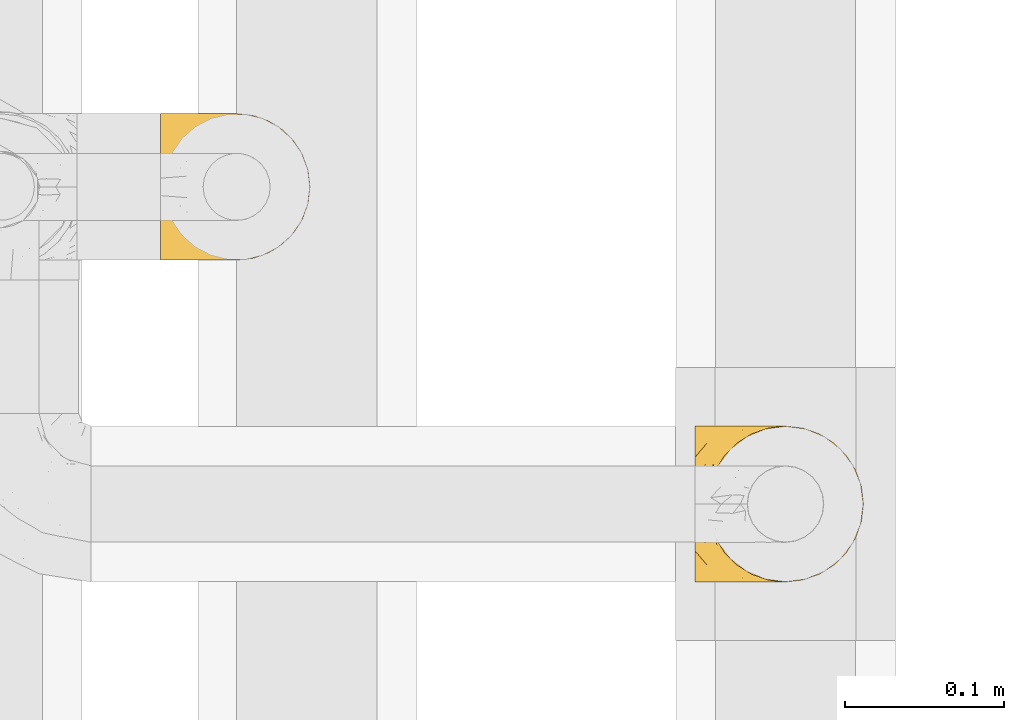
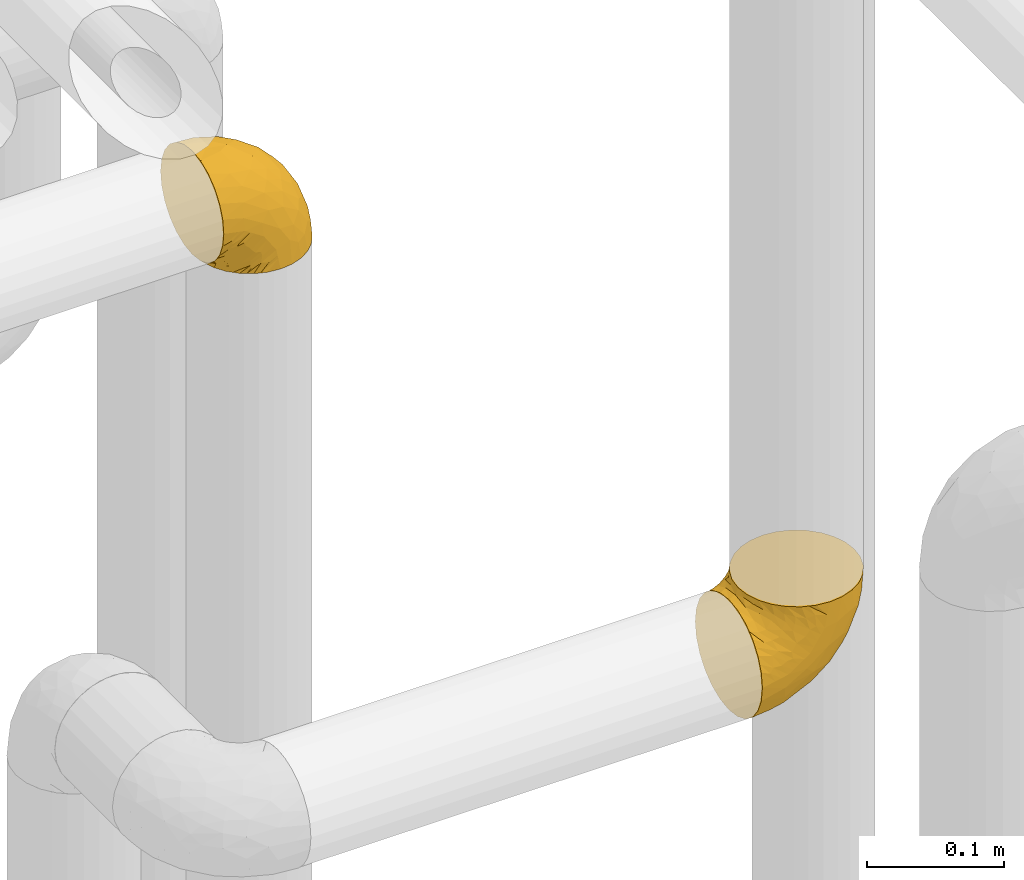
# One storey, part 223 of 827: 2 coverings.
"""IFC2X3 building model written with IfcOpenShell, lengths in millimetres."""

from ifc_helpers import new_model, entity, si_unit, converted_unit, derived_unit, direction, frame, origin, place, context, subcontext, project, spatial, faceted_brep, element, save


model = new_model("IFC2X3")

# Units and contexts
model_context = context("Model", 3, precision=0.01, world=origin(), true_north=direction((6.12303176911189e-17, 1.0)))
body_context = subcontext(model_context, "Body", "Model", "MODEL_VIEW")
ifc_project = project(units=[si_unit("LENGTHUNIT", "METRE", prefix="MILLI"), si_unit("AREAUNIT", "SQUARE_METRE"), si_unit("VOLUMEUNIT", "CUBIC_METRE"), converted_unit("PLANEANGLEUNIT", "DEGREE", entity("IfcRatioMeasure", 0.0174532925199433), si_unit("PLANEANGLEUNIT", "RADIAN"), dimensions=[0, 0, 0, 0, 0, 0, 0]), si_unit("MASSUNIT", "GRAM", prefix="KILO"), derived_unit("MASSDENSITYUNIT", [(si_unit("MASSUNIT", "GRAM", prefix="KILO"), 1), (si_unit("LENGTHUNIT", "METRE"), -3)]), derived_unit("MOMENTOFINERTIAUNIT", [(si_unit("LENGTHUNIT", "METRE"), 4)]), si_unit("TIMEUNIT", "SECOND"), si_unit("FREQUENCYUNIT", "HERTZ"), si_unit("THERMODYNAMICTEMPERATUREUNIT", "DEGREE_CELSIUS"), derived_unit("THERMALTRANSMITTANCEUNIT", [(si_unit("MASSUNIT", "GRAM", prefix="KILO"), 1), (si_unit("THERMODYNAMICTEMPERATUREUNIT", "KELVIN"), -1), (si_unit("TIMEUNIT", "SECOND"), -3)]), derived_unit("VOLUMETRICFLOWRATEUNIT", [(si_unit("LENGTHUNIT", "METRE"), 3), (si_unit("TIMEUNIT", "SECOND"), -1)]), derived_unit("MASSFLOWRATEUNIT", [(si_unit("MASSUNIT", "GRAM", prefix="KILO"), 1), (si_unit("TIMEUNIT", "SECOND"), -1)]), derived_unit("ROTATIONALFREQUENCYUNIT", [(si_unit("TIMEUNIT", "SECOND"), -1)]), si_unit("ELECTRICCURRENTUNIT", "AMPERE"), si_unit("ELECTRICVOLTAGEUNIT", "VOLT"), si_unit("POWERUNIT", "WATT"), si_unit("FORCEUNIT", "NEWTON", prefix="KILO"), si_unit("ILLUMINANCEUNIT", "LUX"), si_unit("LUMINOUSFLUXUNIT", "LUMEN"), si_unit("LUMINOUSINTENSITYUNIT", "CANDELA"), derived_unit("USERDEFINED", [(si_unit("MASSUNIT", "GRAM", prefix="KILO"), -1), (si_unit("LENGTHUNIT", "METRE"), -2), (si_unit("TIMEUNIT", "SECOND"), 3), (si_unit("LUMINOUSFLUXUNIT", "LUMEN"), 1)]), derived_unit("LINEARVELOCITYUNIT", [(si_unit("LENGTHUNIT", "METRE"), 1), (si_unit("TIMEUNIT", "SECOND"), -1)]), si_unit("PRESSUREUNIT", "PASCAL"), derived_unit("USERDEFINED", [(si_unit("LENGTHUNIT", "METRE"), -2), (si_unit("MASSUNIT", "GRAM", prefix="KILO"), 1), (si_unit("TIMEUNIT", "SECOND"), -2)]), derived_unit("LINEARFORCEUNIT", [(si_unit("MASSUNIT", "GRAM", prefix="KILO"), 1), (si_unit("LENGTHUNIT", "METRE"), 1), (si_unit("TIMEUNIT", "SECOND"), -2), (si_unit("LENGTHUNIT", "METRE"), -1)]), derived_unit("PLANARFORCEUNIT", [(si_unit("MASSUNIT", "GRAM", prefix="KILO"), 1), (si_unit("LENGTHUNIT", "METRE"), 1), (si_unit("TIMEUNIT", "SECOND"), -2), (si_unit("LENGTHUNIT", "METRE"), -2)])], contexts=[model_context])

# Site, building, storey
site_placement = place(None, origin())
site = spatial("IfcSite", under=ifc_project, at=site_placement, CompositionType="ELEMENT")
building_placement = place(site_placement, origin())
building = spatial("IfcBuilding", under=site, at=building_placement, CompositionType="ELEMENT")
storey_placement = place(building_placement, frame((0.0, 0.0, 28200.0)))
storey = spatial("IfcBuildingStorey", under=building, at=storey_placement, Name="08", CompositionType="ELEMENT", Elevation=28200.0)

# Coverings
covering_1_placement = place(storey_placement, frame((36161.44, 12505.34, 2549.25)))
element("IfcCovering", 1, at=covering_1_placement, inside=storey, Name=":ADSK_", ObjectType=":ADSK_", PredefinedType="INSULATION", context=body_context, shape_type="Brep", body=[
    faceted_brep([(58.6, 1.6, 107.75), (69.54, 2.83, 107.75), (79.93, 6.47, 107.75), (89.25, 12.32, 107.75), (97.03, 20.11, 107.75), (102.88, 29.43, 107.75), (106.51, 39.81, 107.75), (107.75, 50.75, 107.75), (106.51, 61.69, 107.75), (102.87, 72.08, 107.75), (97.02, 81.4, 107.75), (89.23, 89.18, 107.75), (79.91, 95.03, 107.75), (69.53, 98.66, 107.75), (58.6, 99.9, 107.75), (52.89, 99.25, 107.75), (47.65, 98.66, 107.75), (42.46, 96.84, 107.75), (37.26, 95.02, 107.75), (27.94, 89.17, 107.75), (20.16, 81.38, 107.75), (14.31, 72.06, 107.75), (10.68, 61.68, 107.75), (9.45, 50.75, 107.75), (10.68, 39.8, 107.75), (14.32, 29.41, 107.75), (20.17, 20.09, 107.75), (27.96, 12.31, 107.75), (37.28, 6.46, 107.75), (42.47, 4.64, 107.75), (47.66, 2.83, 107.75), (52.89, 2.24, 107.75), (55.75, 1.92, 107.75), (1.6, 63.47, 98.22), (1.6, 75.32, 93.31), (1.6, 80.41, 89.4), (1.6, 85.5, 85.5), (1.6, 89.4, 80.41), (1.6, 93.31, 75.32), (1.6, 95.77, 69.39), (1.6, 98.22, 63.47), (1.6, 99.14, 56.48), (1.6, 99.52, 53.61), (1.6, 99.9, 50.75), (1.6, 98.22, 38.02), (1.6, 93.31, 26.17), (1.6, 85.5, 15.99), (1.6, 75.32, 8.18), (1.6, 63.47, 3.27), (1.6, 50.75, 1.6), (1.6, 38.02, 3.27), (1.6, 26.17, 8.18), (1.6, 15.99, 15.99), (1.6, 8.18, 26.17), (1.6, 3.27, 38.02), (1.6, 1.6, 50.75), (1.6, 2.35, 56.48), (1.6, 3.27, 63.47), (1.6, 5.73, 69.39), (1.6, 8.18, 75.32), (1.6, 12.09, 80.41), (1.6, 15.99, 85.5), (1.6, 21.08, 89.4), (1.6, 26.17, 93.31), (1.6, 38.02, 98.22), (1.6, 50.75, 99.9), (69.96, 42.18, 27.53), (59.59, 28.42, 25.32), (51.96, 37.78, 16.29), (34.4, 50.75, 6.79), (23.37, 42.85, 4.51), (13.68, 50.75, 3.51), (41.52, 24.75, 17.47), (26.26, 33.81, 7.6), (20.18, 22.57, 12.27), (72.33, 7.18, 70.89), (65.88, 2.73, 87.17), (57.55, 3.09, 67.3), (23.76, 6.92, 31.65), (46.5, 11.58, 33.58), (46.57, 5.17, 47.23), (21.17, 2.71, 43.26), (23.41, 1.6, 55.08), (17.92, 1.6, 53.99), (12.43, 1.6, 52.9), (9.72, 1.6, 52.36), (7.01, 1.6, 51.82), (26.77, 14.18, 21.5), (76.59, 5.88, 89.94), (95.55, 41.06, 60.45), (102.57, 36.25, 83.0), (92.89, 28.62, 64.79), (54.26, 1.6, 85.93), (51.17, 1.6, 81.31), (48.08, 1.6, 76.69), (44.99, 1.6, 72.06), (41.9, 1.6, 67.44), (85.16, 10.85, 88.74), (85.97, 38.35, 45.98), (59.58, 9.6, 47.13), (99.5, 26.24, 89.4), (105.83, 50.75, 95.66), (53.59, 19.31, 28.5), (67.0, 16.41, 42.81), (71.56, 24.56, 38.28), (87.47, 50.75, 45.35), (75.73, 50.75, 33.61), (92.24, 18.47, 82.57), (58.06, 1.6, 105.04), (57.52, 1.6, 102.33), (56.44, 1.6, 96.91), (55.35, 1.6, 91.42), (81.33, 14.36, 65.92), (80.35, 20.64, 53.11), (39.44, 2.32, 54.37), (102.55, 50.75, 74.94), (37.28, 1.6, 64.35), (32.65, 1.6, 61.26), (28.03, 1.6, 58.17), (63.99, 50.75, 21.87), (74.55, 33.88, 34.79), (83.62, 29.24, 48.48), (95.01, 50.75, 60.15), (49.19, 50.75, 14.33), (46.96, 2.8, 99.07), (8.77, 2.48, 60.55), (18.28, 2.7, 64.18), (11.68, 3.2, 64.36), (11.79, 32.98, 103.17), (15.69, 24.67, 101.69), (42.49, 2.95, 87.75), (47.41, 2.19, 89.38), (7.94, 17.92, 88.34), (9.27, 12.02, 82.14), (7.98, 25.73, 94.51), (13.4, 16.63, 89.64), (13.04, 25.6, 98.41), (7.36, 36.72, 99.71), (23.46, 10.66, 89.37), (30.46, 6.87, 88.21), (26.54, 11.12, 95.2), (6.76, 10.31, 79.14), (26.46, 12.84, 101.22), (20.77, 17.38, 99.41), (20.68, 9.74, 84.72), (40.26, 4.63, 97.47), (7.15, 50.75, 102.19), (9.28, 42.52, 104.02), (38.78, 3.12, 82.66), (18.27, 17.58, 95.42), (31.78, 3.97, 78.67), (12.75, 5.94, 72.69), (22.96, 2.73, 66.46), (17.55, 6.23, 75.3), (27.63, 3.45, 72.74), (15.23, 10.84, 82.93), (33.25, 7.98, 99.27), (32.43, 7.33, 93.51), (27.9, 2.39, 67.35), (7.97, 75.76, 94.51), (15.22, 90.65, 82.94), (7.93, 83.57, 88.33), (13.38, 84.85, 89.64), (13.12, 71.05, 103.62), (42.49, 98.54, 87.74), (47.4, 99.3, 89.38), (51.17, 99.9, 81.31), (40.24, 96.86, 97.47), (20.76, 84.1, 99.41), (12.43, 99.9, 52.9), (7.01, 99.9, 51.82), (4.31, 99.9, 51.28), (26.44, 88.63, 101.21), (26.52, 90.36, 95.19), (11.68, 98.29, 64.36), (12.75, 95.55, 72.69), (9.27, 89.47, 82.13), (17.55, 95.26, 75.3), (6.76, 91.18, 79.14), (33.21, 93.49, 99.28), (32.41, 94.15, 93.51), (8.77, 99.01, 60.55), (22.96, 98.76, 66.46), (18.48, 98.85, 63.96), (56.44, 99.9, 96.91), (46.95, 98.69, 99.06), (7.36, 64.78, 99.7), (17.92, 99.9, 53.99), (23.41, 99.9, 55.08), (9.85, 62.91, 103.3), (57.52, 99.9, 102.33), (56.98, 99.9, 99.62), (48.08, 99.9, 76.69), (38.78, 98.37, 82.66), (18.25, 83.9, 95.42), (44.99, 99.9, 72.06), (31.74, 97.51, 78.68), (30.45, 94.62, 88.2), (27.63, 98.04, 72.75), (20.65, 91.73, 84.74), (55.35, 99.9, 91.42), (54.26, 99.9, 85.93), (13.03, 75.87, 98.41), (23.44, 90.83, 89.37), (27.9, 99.1, 67.35), (32.65, 99.9, 61.26), (28.03, 99.9, 58.17), (37.28, 99.9, 64.35), (41.9, 99.9, 67.44), (39.74, 99.09, 54.08), (23.37, 58.64, 4.51), (26.77, 87.31, 21.5), (46.18, 89.93, 33.43), (53.54, 82.22, 28.5), (41.53, 76.74, 17.47), (59.61, 73.12, 25.36), (76.79, 95.54, 90.18), (66.11, 98.7, 86.97), (21.17, 98.79, 43.26), (51.96, 63.71, 16.29), (26.26, 67.68, 7.6), (20.18, 78.92, 12.27), (23.76, 94.57, 31.65), (92.88, 72.88, 64.79), (102.57, 65.25, 83.0), (95.54, 60.44, 60.44), (71.63, 76.94, 38.35), (74.55, 67.61, 34.8), (72.51, 94.38, 71.54), (69.96, 59.31, 27.53), (92.23, 83.03, 82.57), (85.15, 90.66, 88.74), (80.45, 80.8, 53.19), (83.65, 72.22, 48.49), (57.57, 98.39, 67.28), (63.68, 92.31, 52.32), (85.95, 63.11, 45.94), (99.49, 75.27, 89.4), (81.23, 87.15, 65.75), (47.07, 96.03, 46.73), (66.99, 85.1, 42.82)], [[[0, 1, 2, 3, 4, 5, 6, 7, 8, 9, 10, 11, 12, 13, 14, 15, 16, 17, 18, 19, 20, 21, 22, 23, 24, 25, 26, 27, 28, 29, 30, 31, 32]], [[33, 34, 35, 36, 37, 38, 39, 40, 41, 42, 43, 44, 45, 46, 47, 48, 49, 50, 51, 52, 53, 54, 55, 56, 57, 58, 59, 60, 61, 62, 63, 64, 65]], [[66, 67, 68]], [[69, 70, 71]], [[68, 72, 73]], [[73, 72, 74]], [[75, 76, 77]], [[78, 79, 80]], [[51, 50, 73]], [[81, 82, 83, 84, 85, 86, 55]], [[52, 87, 53]], [[74, 52, 51]], [[2, 1, 88]], [[89, 90, 91]], [[77, 92, 93, 94, 95, 96]], [[55, 54, 81]], [[78, 53, 87]], [[5, 90, 6]], [[88, 76, 75]], [[97, 3, 2]], [[89, 91, 98]], [[99, 80, 79]], [[90, 5, 100]], [[74, 87, 52]], [[100, 5, 4]], [[90, 101, 6]], [[79, 102, 103]], [[102, 67, 104]], [[105, 98, 106]], [[107, 4, 3]], [[76, 0, 108, 109, 110, 111, 92]], [[107, 112, 113]], [[114, 77, 96]], [[89, 115, 90]], [[114, 96, 116, 117, 118, 82]], [[75, 97, 88]], [[119, 66, 68]], [[50, 71, 70]], [[100, 91, 90]], [[99, 77, 80]], [[102, 104, 103]], [[97, 107, 3]], [[80, 81, 78]], [[107, 97, 112]], [[68, 73, 70]], [[66, 98, 120]], [[78, 81, 54]], [[114, 81, 80]], [[53, 78, 54]], [[78, 87, 79]], [[102, 87, 72]], [[79, 103, 99]], [[4, 107, 100]], [[91, 100, 107]], [[88, 97, 2]], [[112, 97, 75]], [[99, 112, 75]], [[103, 104, 113]], [[91, 121, 98]], [[89, 105, 122, 115]], [[101, 90, 115]], [[101, 7, 6]], [[88, 1, 76]], [[0, 76, 1]], [[92, 77, 76]], [[73, 74, 51]], [[87, 74, 72]], [[81, 114, 82]], [[77, 114, 80]], [[87, 102, 79]], [[67, 102, 72]], [[68, 67, 72]], [[67, 120, 104]], [[120, 121, 104]], [[104, 121, 113]], [[121, 120, 98]], [[91, 107, 113]], [[91, 113, 121]], [[103, 113, 112]], [[106, 98, 66]], [[105, 89, 98]], [[106, 66, 119]], [[67, 66, 120]], [[68, 69, 123, 119]], [[50, 49, 71]], [[50, 70, 73]], [[112, 99, 103]], [[77, 99, 75]], [[69, 68, 70]], [[29, 124, 110]], [[84, 83, 125]], [[126, 82, 118]], [[59, 58, 127]], [[25, 128, 129]], [[130, 93, 131]], [[132, 62, 133]], [[134, 135, 136]], [[137, 65, 64]], [[64, 134, 137]], [[138, 139, 140]], [[111, 110, 124, 92]], [[134, 136, 137]], [[134, 64, 63]], [[141, 61, 60]], [[125, 58, 57]], [[142, 143, 140]], [[142, 26, 143]], [[127, 83, 82]], [[28, 124, 29]], [[108, 0, 32, 31, 30, 110, 109]], [[30, 29, 110]], [[135, 144, 138]], [[28, 145, 124]], [[57, 56, 55, 86, 85, 84]], [[146, 147, 23]], [[24, 23, 147]], [[25, 143, 26]], [[95, 94, 148]], [[24, 128, 25]], [[149, 138, 143]], [[124, 145, 131]], [[127, 58, 125]], [[150, 148, 139]], [[127, 126, 151]], [[151, 59, 127]], [[152, 151, 126]], [[153, 154, 155]], [[153, 133, 141]], [[145, 28, 27]], [[142, 156, 27]], [[157, 148, 130]], [[61, 133, 62]], [[134, 132, 135]], [[147, 128, 24]], [[65, 137, 146]], [[146, 137, 147]], [[128, 137, 136]], [[137, 128, 147]], [[128, 136, 129]], [[149, 129, 136]], [[25, 129, 143]], [[158, 152, 117]], [[152, 118, 117]], [[153, 151, 152]], [[158, 116, 154]], [[144, 150, 138]], [[153, 152, 158]], [[133, 153, 155]], [[133, 155, 132]], [[60, 151, 141]], [[135, 132, 155]], [[134, 63, 132]], [[144, 135, 155]], [[135, 138, 149]], [[155, 154, 144]], [[150, 154, 96]], [[154, 150, 144]], [[148, 94, 130]], [[82, 126, 127]], [[118, 152, 126]], [[150, 96, 95]], [[139, 148, 157]], [[150, 95, 148]], [[93, 92, 131]], [[130, 145, 156]], [[130, 94, 93]], [[84, 125, 57]], [[127, 125, 83]], [[140, 139, 157]], [[150, 139, 138]], [[140, 157, 142]], [[138, 140, 143]], [[156, 142, 157]], [[27, 26, 142]], [[130, 156, 157]], [[145, 27, 156]], [[132, 63, 62]], [[124, 131, 92]], [[130, 131, 145]], [[129, 149, 143]], [[135, 149, 136]], [[141, 133, 61]], [[60, 59, 151]], [[141, 151, 153]], [[116, 96, 154]], [[153, 158, 154]], [[158, 117, 116]], [[34, 33, 159]], [[160, 161, 162]], [[22, 21, 163]], [[164, 165, 166]], [[19, 18, 167]], [[168, 21, 20]], [[42, 41, 40, 169, 170, 171, 43]], [[172, 173, 168]], [[174, 38, 175]], [[176, 177, 178]], [[179, 164, 180]], [[40, 181, 169]], [[182, 183, 175]], [[17, 184, 185]], [[65, 146, 186]], [[187, 174, 188]], [[23, 22, 189]], [[174, 39, 38]], [[15, 14, 190, 191, 184, 16]], [[181, 40, 39]], [[192, 193, 164]], [[194, 163, 168]], [[33, 186, 159]], [[180, 173, 172]], [[195, 196, 193]], [[18, 185, 167]], [[173, 180, 197]], [[198, 199, 196]], [[200, 201, 185, 184]], [[184, 17, 16]], [[18, 17, 185]], [[202, 159, 186]], [[194, 168, 203]], [[189, 163, 202]], [[204, 205, 182]], [[187, 181, 174]], [[160, 177, 176]], [[206, 183, 182]], [[206, 182, 205]], [[201, 165, 185]], [[165, 164, 167]], [[172, 179, 180]], [[202, 194, 162]], [[176, 161, 160]], [[65, 186, 33]], [[163, 189, 22]], [[175, 177, 182]], [[174, 183, 188]], [[177, 198, 204]], [[199, 160, 162]], [[198, 207, 204]], [[175, 38, 37]], [[198, 177, 160]], [[178, 177, 175]], [[176, 35, 161]], [[34, 159, 161]], [[162, 161, 159]], [[202, 162, 159]], [[199, 162, 203]], [[196, 199, 203]], [[198, 160, 199]], [[193, 197, 180]], [[208, 198, 196]], [[188, 183, 206]], [[175, 183, 174]], [[193, 192, 195]], [[195, 208, 196]], [[197, 196, 203]], [[180, 164, 193]], [[168, 163, 21]], [[166, 165, 201]], [[166, 192, 164]], [[189, 202, 186]], [[186, 146, 189]], [[23, 189, 146]], [[174, 181, 39]], [[169, 181, 187]], [[196, 197, 193]], [[173, 203, 168]], [[203, 173, 197]], [[172, 168, 20]], [[20, 19, 172]], [[179, 172, 19]], [[19, 167, 179]], [[164, 179, 167]], [[35, 176, 36]], [[35, 34, 161]], [[185, 165, 167]], [[162, 194, 203]], [[163, 194, 202]], [[176, 178, 36]], [[37, 36, 178]], [[175, 37, 178]], [[177, 204, 182]], [[207, 198, 208]], [[207, 205, 204]], [[209, 188, 206, 205, 207, 208]], [[48, 210, 71]], [[211, 212, 213]], [[214, 213, 215]], [[216, 217, 13]], [[218, 43, 171, 170, 169, 187, 188]], [[219, 220, 214]], [[47, 46, 221]], [[210, 48, 220]], [[211, 222, 212]], [[222, 45, 44]], [[221, 220, 47]], [[47, 220, 48]], [[221, 211, 214]], [[223, 224, 225]], [[211, 46, 45]], [[226, 227, 215]], [[43, 218, 44]], [[217, 216, 228]], [[219, 215, 229]], [[14, 13, 217]], [[224, 9, 8]], [[10, 230, 11]], [[11, 231, 12]], [[232, 223, 233]], [[234, 208, 195, 192, 166, 201]], [[235, 234, 228]], [[222, 44, 218]], [[106, 229, 236]], [[224, 237, 9]], [[231, 238, 228]], [[9, 237, 10]], [[115, 224, 101]], [[239, 234, 235]], [[231, 11, 230]], [[223, 230, 237]], [[224, 8, 101]], [[223, 236, 233]], [[225, 115, 122, 105]], [[216, 12, 231]], [[209, 234, 239]], [[210, 219, 69]], [[219, 214, 215]], [[229, 119, 219]], [[209, 218, 188]], [[239, 212, 222]], [[239, 222, 218]], [[45, 222, 211]], [[235, 212, 239]], [[213, 212, 240]], [[223, 237, 224]], [[230, 10, 237]], [[238, 231, 230]], [[216, 231, 228]], [[232, 230, 223]], [[235, 238, 240]], [[115, 225, 224]], [[233, 236, 227]], [[8, 7, 101]], [[234, 209, 208]], [[218, 209, 239]], [[217, 228, 234]], [[13, 12, 216]], [[234, 201, 217]], [[217, 201, 200, 184, 191, 190, 14]], [[211, 221, 46]], [[220, 221, 214]], [[71, 210, 69]], [[71, 49, 48]], [[219, 210, 220]], [[226, 215, 213]], [[211, 213, 214]], [[226, 213, 240]], [[215, 227, 229]], [[232, 240, 238]], [[233, 227, 226]], [[232, 233, 226]], [[236, 223, 225]], [[240, 232, 226]], [[232, 238, 230]], [[225, 105, 236]], [[236, 105, 106]], [[236, 229, 227]], [[123, 69, 219, 119]], [[106, 119, 229]], [[238, 235, 228]], [[212, 235, 240]]]),
])
covering_2_placement = place(storey_placement, frame((35824.19, 12708.37, 2950.4)))
element("IfcCovering", 2, at=covering_2_placement, inside=storey, Name=":ADSK_", ObjectType=":ADSK_", PredefinedType="INSULATION", context=body_context, shape_type="Brep", body=[
    faceted_brep([(78.41, 83.91, 1.6), (85.72, 76.59, 1.6), (91.22, 67.83, 1.6), (94.64, 58.07, 1.6), (95.8, 47.8, 1.6), (94.64, 37.51, 1.6), (91.22, 27.74, 1.6), (85.71, 18.98, 1.6), (78.39, 11.67, 1.6), (69.63, 6.17, 1.6), (59.87, 2.75, 1.6), (49.6, 1.6, 1.6), (45.45, 2.06, 1.6), (42.38, 2.41, 1.6), (39.31, 2.75, 1.6), (34.43, 4.46, 1.6), (29.54, 6.17, 1.6), (25.16, 8.93, 1.6), (20.78, 11.68, 1.6), (17.13, 15.34, 1.6), (13.47, 19.0, 1.6), (7.97, 27.76, 1.6), (6.26, 32.64, 1.6), (4.55, 37.52, 1.6), (3.4, 47.8, 1.6), (4.55, 58.08, 1.6), (6.26, 62.96, 1.6), (7.97, 67.85, 1.6), (13.48, 76.61, 1.6), (17.14, 80.26, 1.6), (20.8, 83.92, 1.6), (25.18, 86.67, 1.6), (29.56, 89.42, 1.6), (34.44, 91.13, 1.6), (39.32, 92.84, 1.6), (42.39, 93.18, 1.6), (45.45, 93.53, 1.6), (49.6, 94.0, 1.6), (59.88, 92.84, 1.6), (69.65, 89.42, 1.6), (1.6, 47.8, 3.4), (1.6, 35.84, 4.97), (1.6, 24.7, 9.58), (1.6, 19.91, 13.26), (1.6, 15.13, 16.93), (1.6, 11.46, 21.71), (1.6, 7.78, 26.5), (1.6, 5.48, 32.07), (1.6, 3.17, 37.64), (1.6, 2.69, 41.25), (1.6, 2.42, 43.34), (1.6, 2.14, 45.42), (1.6, 1.6, 49.6), (1.6, 3.17, 61.55), (1.6, 7.78, 72.7), (1.6, 15.13, 82.26), (1.6, 24.7, 89.61), (1.6, 35.84, 94.22), (1.6, 47.8, 95.8), (1.6, 59.75, 94.22), (1.6, 70.9, 89.61), (1.6, 80.46, 82.26), (1.6, 87.81, 72.7), (1.6, 92.42, 61.55), (1.6, 94.0, 49.6), (1.6, 93.45, 45.42), (1.6, 92.9, 41.25), (1.6, 92.42, 37.64), (1.6, 90.11, 32.07), (1.6, 87.81, 26.5), (1.6, 84.13, 21.71), (1.6, 80.46, 16.93), (1.6, 75.68, 13.26), (1.6, 70.9, 9.58), (1.6, 59.75, 4.97), (36.81, 71.98, 81.55), (23.28, 63.6, 90.4), (45.8, 59.72, 83.0), (30.7, 47.8, 91.18), (21.2, 55.16, 93.13), (12.96, 47.8, 94.0), (66.19, 63.76, 66.19), (54.51, 72.22, 70.92), (17.98, 74.18, 85.95), (36.69, 92.52, 49.74), (35.54, 94.0, 35.54), (31.64, 94.0, 38.14), (27.75, 94.0, 40.74), (23.86, 94.0, 43.34), (19.96, 94.0, 45.94), (22.8, 82.14, 77.59), (42.67, 80.34, 71.17), (33.21, 87.52, 65.81), (59.45, 79.59, 59.03), (71.5, 78.25, 45.85), (62.66, 85.01, 45.79), (54.5, 90.25, 41.42), (47.57, 93.2, 34.51), (48.81, 87.23, 56.04), (74.98, 85.55, 15.15), (18.7, 93.0, 56.51), (15.75, 89.31, 68.39), (91.17, 61.31, 23.33), (85.28, 56.86, 42.86), (82.58, 68.34, 39.42), (75.78, 65.71, 53.58), (74.98, 56.99, 59.17), (67.27, 72.15, 59.06), (87.38, 70.34, 22.63), (82.04, 78.36, 20.55), (94.0, 47.8, 12.96), (77.8, 47.8, 56.96), (67.38, 47.8, 67.38), (56.2, 93.06, 18.72), (48.85, 94.0, 5.33), (48.11, 94.0, 9.07), (47.57, 94.0, 11.79), (47.03, 94.0, 14.51), (46.48, 94.0, 17.24), (45.94, 94.0, 19.96), (65.78, 89.88, 21.03), (17.24, 94.0, 46.48), (14.51, 94.0, 47.03), (11.79, 94.0, 47.57), (9.07, 94.0, 48.11), (7.2, 94.0, 48.48), (5.33, 94.0, 48.85), (91.18, 47.8, 30.7), (43.34, 94.0, 23.86), (40.74, 94.0, 27.75), (38.14, 94.0, 31.64), (72.73, 83.7, 31.26), (56.96, 47.8, 77.8), (62.23, 55.9, 72.75), (84.49, 47.8, 43.83), (43.83, 47.8, 84.49), (12.05, 81.75, 14.58), (18.95, 86.43, 16.17), (13.02, 79.8, 10.82), (8.34, 69.84, 4.64), (14.63, 79.5, 7.71), (11.09, 88.08, 25.13), (13.66, 91.6, 32.66), (20.08, 92.93, 34.94), (9.61, 92.43, 36.76), (9.48, 93.24, 40.48), (16.1, 93.36, 39.25), (3.42, 57.25, 3.69), (26.63, 89.41, 13.99), (33.72, 92.89, 21.85), (34.77, 92.66, 17.93), (6.75, 79.58, 15.11), (13.31, 86.51, 21.14), (21.11, 86.29, 12.7), (19.94, 83.91, 7.21), (8.67, 90.94, 32.27), (26.11, 91.94, 25.68), (29.3, 91.98, 22.18), (6.32, 82.79, 18.79), (39.92, 93.16, 10.12), (27.05, 88.76, 9.47), (6.04, 73.94, 10.45), (34.4, 91.89, 11.29), (2.87, 47.8, 2.87), (20.92, 92.22, 31.16), (27.43, 88.56, 6.31), (7.54, 87.72, 25.62), (18.45, 88.33, 21.18), (23.88, 92.18, 28.81), (7.77, 71.78, 7.45), (13.3, 9.09, 21.14), (11.09, 7.51, 25.13), (6.33, 12.8, 18.79), (9.07, 1.6, 48.11), (5.33, 1.6, 48.85), (14.51, 1.6, 47.03), (11.79, 1.6, 47.57), (3.42, 38.35, 3.69), (7.76, 23.84, 7.44), (47.03, 1.6, 14.51), (47.57, 1.6, 11.79), (48.85, 1.6, 5.33), (48.11, 1.6, 9.07), (14.62, 16.1, 7.71), (27.03, 6.84, 9.47), (20.08, 2.66, 34.94), (20.92, 3.37, 31.16), (27.75, 1.6, 40.74), (31.64, 1.6, 38.14), (9.61, 3.16, 36.76), (9.48, 2.35, 40.48), (8.33, 25.77, 4.63), (6.74, 16.02, 15.11), (12.04, 13.85, 14.58), (23.86, 1.6, 43.34), (19.96, 1.6, 45.94), (16.1, 2.23, 39.25), (19.93, 11.69, 7.21), (21.1, 9.31, 12.69), (39.92, 2.43, 10.14), (33.68, 2.71, 21.81), (29.28, 3.61, 22.19), (26.62, 6.18, 14.0), (26.08, 3.66, 25.69), (18.93, 9.17, 16.17), (27.87, 6.77, 6.66), (34.75, 2.93, 17.92), (6.04, 21.66, 10.45), (38.14, 1.6, 31.64), (12.79, 16.09, 10.64), (34.41, 3.7, 11.31), (45.94, 1.6, 19.96), (43.34, 1.6, 23.86), (40.74, 1.6, 27.75), (13.66, 3.99, 32.66), (17.24, 1.6, 46.48), (8.67, 4.65, 32.27), (35.54, 1.6, 35.54), (23.83, 3.43, 28.77), (18.43, 7.27, 21.17), (6.03, 9.46, 23.36), (46.48, 1.6, 17.24), (34.52, 2.4, 47.58), (21.2, 40.43, 93.13), (23.82, 13.57, 77.44), (41.32, 11.3, 66.78), (47.62, 18.65, 71.68), (52.66, 27.26, 74.96), (36.81, 23.61, 81.55), (49.75, 3.07, 36.7), (19.07, 2.69, 56.9), (45.8, 35.87, 83.0), (23.28, 31.99, 90.4), (21.35, 6.71, 67.83), (17.98, 21.41, 85.95), (82.57, 27.24, 39.41), (91.17, 34.26, 23.33), (85.27, 38.73, 42.87), (73.89, 26.97, 53.92), (66.19, 31.83, 66.19), (62.43, 23.4, 64.12), (63.53, 6.91, 33.13), (58.45, 3.4, 23.1), (67.16, 5.84, 16.98), (62.22, 39.69, 72.75), (81.54, 17.6, 23.77), (74.8, 10.38, 18.41), (75.83, 20.6, 43.7), (41.45, 5.36, 54.53), (76.72, 35.73, 55.72), (88.2, 24.84, 17.73), (71.6, 13.87, 38.98), (56.23, 9.06, 50.28), (59.44, 15.99, 59.02)], [[[0, 1, 2, 3, 4, 5, 6, 7, 8, 9, 10, 11, 12, 13, 14, 15, 16, 17, 18, 19, 20, 21, 22, 23, 24, 25, 26, 27, 28, 29, 30, 31, 32, 33, 34, 35, 36, 37, 38, 39]], [[40, 41, 42, 43, 44, 45, 46, 47, 48, 49, 50, 51, 52, 53, 54, 55, 56, 57, 58, 59, 60, 61, 62, 63, 64, 65, 66, 67, 68, 69, 70, 71, 72, 73, 74]], [[75, 76, 77]], [[78, 79, 80]], [[77, 81, 82]], [[76, 75, 83]], [[84, 85, 86, 87, 88, 89]], [[90, 91, 92]], [[76, 60, 59]], [[93, 94, 95]], [[90, 62, 61]], [[83, 61, 60]], [[96, 97, 84]], [[98, 93, 95]], [[0, 39, 99]], [[100, 84, 89]], [[62, 101, 63]], [[2, 102, 3]], [[92, 84, 100]], [[103, 102, 104]], [[103, 105, 106]], [[93, 107, 94]], [[1, 108, 2]], [[92, 101, 90]], [[108, 1, 109]], [[102, 110, 3]], [[93, 82, 107]], [[102, 108, 104]], [[111, 106, 112]], [[109, 0, 99]], [[113, 37, 114, 115, 116, 117, 118, 119]], [[120, 38, 113]], [[100, 89, 121, 122, 123, 124, 125, 126, 64]], [[127, 102, 103]], [[97, 119, 128, 129, 130, 85]], [[99, 120, 131]], [[132, 133, 77]], [[59, 80, 79]], [[1, 0, 109]], [[98, 84, 92]], [[94, 109, 131]], [[120, 39, 38]], [[93, 91, 82]], [[104, 94, 105]], [[97, 113, 119]], [[95, 120, 96]], [[83, 90, 61]], [[91, 93, 98]], [[64, 63, 100]], [[100, 63, 101]], [[77, 76, 79]], [[133, 106, 81]], [[84, 97, 85]], [[113, 96, 120]], [[113, 97, 96]], [[37, 113, 38]], [[110, 102, 127]], [[110, 4, 3]], [[103, 111, 134, 127]], [[90, 75, 91]], [[82, 81, 107]], [[91, 75, 82]], [[77, 82, 75]], [[76, 83, 60]], [[90, 83, 75]], [[105, 107, 81]], [[94, 131, 95]], [[105, 94, 107]], [[109, 94, 104]], [[120, 95, 131]], [[98, 95, 96]], [[84, 98, 96]], [[98, 92, 91]], [[106, 105, 81]], [[103, 104, 105]], [[112, 106, 133]], [[103, 106, 111]], [[112, 133, 132]], [[81, 77, 133]], [[77, 78, 135, 132]], [[120, 99, 39]], [[109, 99, 131]], [[59, 58, 80]], [[59, 79, 76]], [[90, 101, 62]], [[100, 101, 92]], [[2, 108, 102]], [[109, 104, 108]], [[78, 77, 79]], [[136, 137, 138]], [[27, 139, 140]], [[141, 142, 143]], [[144, 145, 121]], [[146, 89, 88]], [[147, 139, 25]], [[148, 149, 150]], [[136, 151, 152]], [[147, 40, 74]], [[24, 147, 25]], [[140, 153, 154]], [[33, 116, 34]], [[73, 72, 151]], [[114, 37, 36, 35, 34, 116, 115]], [[146, 155, 144]], [[156, 85, 130]], [[157, 149, 148]], [[151, 158, 152]], [[117, 33, 159]], [[29, 154, 160]], [[161, 74, 73]], [[162, 128, 119]], [[66, 65, 64, 126, 125, 124, 123, 122, 67]], [[163, 147, 24]], [[27, 140, 28]], [[149, 129, 150]], [[139, 27, 26, 25]], [[68, 144, 69]], [[129, 128, 150]], [[164, 87, 86]], [[130, 129, 149]], [[122, 145, 67]], [[154, 153, 148]], [[162, 119, 159]], [[165, 30, 160]], [[150, 160, 148]], [[128, 162, 150]], [[30, 165, 31]], [[145, 144, 68]], [[89, 146, 144]], [[87, 164, 143]], [[166, 155, 142]], [[88, 87, 143]], [[162, 160, 150]], [[160, 30, 29]], [[154, 29, 28]], [[140, 154, 28]], [[160, 154, 148]], [[140, 137, 153]], [[157, 148, 153]], [[156, 130, 157]], [[153, 137, 157]], [[157, 137, 156]], [[167, 137, 136]], [[168, 85, 156]], [[152, 168, 167]], [[167, 168, 156]], [[164, 152, 141]], [[71, 158, 72]], [[152, 167, 136]], [[88, 142, 146]], [[144, 155, 69]], [[146, 142, 155]], [[70, 166, 71]], [[142, 141, 166]], [[70, 69, 155]], [[141, 158, 71]], [[161, 73, 151]], [[138, 137, 140]], [[161, 136, 169]], [[136, 161, 151]], [[74, 161, 169]], [[152, 158, 141]], [[151, 72, 158]], [[168, 152, 164]], [[137, 167, 156]], [[164, 86, 168]], [[85, 168, 86]], [[116, 33, 117]], [[130, 149, 157]], [[67, 145, 68]], [[121, 89, 144]], [[145, 122, 121]], [[40, 147, 163]], [[169, 147, 74]], [[159, 33, 32]], [[162, 159, 32]], [[159, 119, 118, 117]], [[139, 147, 169]], [[139, 169, 138]], [[162, 32, 31]], [[141, 143, 164]], [[88, 143, 142]], [[71, 166, 141]], [[155, 166, 70]], [[139, 138, 140]], [[169, 136, 138]], [[160, 162, 165]], [[162, 31, 165]], [[170, 171, 172]], [[173, 174, 52, 51, 50, 49, 48, 175, 176]], [[177, 178, 41]], [[179, 15, 180]], [[12, 11, 181, 182, 180, 14, 13]], [[183, 21, 20]], [[19, 18, 184]], [[185, 186, 187]], [[186, 188, 187]], [[43, 172, 44]], [[189, 190, 47]], [[23, 22, 21, 191]], [[170, 192, 193]], [[40, 163, 177]], [[194, 195, 196]], [[24, 23, 177]], [[197, 198, 183]], [[199, 15, 179]], [[47, 46, 189]], [[200, 201, 202]], [[201, 203, 204]], [[205, 206, 184]], [[207, 41, 178]], [[16, 15, 199]], [[14, 180, 15]], [[202, 201, 198]], [[208, 201, 200]], [[163, 24, 177]], [[48, 47, 190]], [[196, 195, 189]], [[197, 184, 202]], [[204, 193, 209]], [[210, 211, 212]], [[206, 212, 213]], [[205, 17, 210]], [[184, 206, 202]], [[210, 212, 206]], [[185, 194, 214]], [[189, 215, 190]], [[216, 45, 214]], [[186, 171, 170]], [[189, 216, 196]], [[197, 20, 19]], [[194, 185, 187]], [[197, 183, 20]], [[184, 197, 19]], [[197, 202, 198]], [[206, 200, 202]], [[204, 183, 198]], [[201, 208, 203]], [[203, 208, 217]], [[204, 198, 201]], [[217, 188, 218]], [[193, 219, 170]], [[171, 186, 185]], [[170, 218, 186]], [[170, 219, 218]], [[42, 207, 192]], [[171, 220, 172]], [[216, 189, 46]], [[214, 194, 196]], [[44, 220, 45]], [[214, 196, 216]], [[216, 46, 45]], [[214, 45, 220]], [[192, 43, 42]], [[204, 203, 219]], [[207, 193, 192]], [[209, 193, 178]], [[41, 207, 42]], [[193, 207, 178]], [[43, 192, 172]], [[170, 172, 192]], [[204, 219, 193]], [[219, 203, 218]], [[217, 218, 203]], [[188, 186, 218]], [[206, 213, 200]], [[208, 200, 213]], [[199, 210, 16]], [[215, 189, 195]], [[215, 175, 190]], [[175, 48, 190]], [[199, 179, 221, 211]], [[210, 199, 211]], [[23, 191, 177]], [[40, 177, 41]], [[178, 177, 191]], [[21, 183, 191]], [[209, 191, 183]], [[205, 18, 17]], [[17, 16, 210]], [[171, 185, 214]], [[172, 220, 44]], [[214, 220, 171]], [[191, 209, 178]], [[204, 209, 183]], [[206, 205, 210]], [[18, 205, 184]], [[222, 195, 194, 187, 188, 217]], [[57, 223, 80]], [[224, 225, 226]], [[226, 227, 228]], [[229, 217, 208, 213, 212, 211]], [[230, 52, 174, 173, 176, 175, 215, 195]], [[231, 232, 228]], [[231, 78, 223]], [[223, 57, 232]], [[224, 233, 225]], [[233, 54, 53]], [[234, 232, 56]], [[56, 55, 234]], [[234, 224, 228]], [[235, 236, 237]], [[224, 55, 54]], [[238, 239, 240]], [[52, 230, 53]], [[241, 242, 243]], [[227, 244, 231]], [[11, 10, 242]], [[236, 6, 5]], [[7, 245, 8]], [[8, 246, 9]], [[238, 247, 235]], [[222, 229, 248]], [[242, 211, 221, 179, 180, 182, 181, 11]], [[233, 53, 230]], [[111, 112, 249]], [[250, 6, 236]], [[246, 251, 241]], [[6, 250, 7]], [[127, 236, 110]], [[248, 229, 252]], [[246, 8, 245]], [[235, 245, 250]], [[236, 5, 110]], [[235, 249, 238]], [[237, 236, 127]], [[243, 9, 246]], [[252, 229, 241]], [[56, 232, 57]], [[222, 230, 195]], [[225, 248, 252]], [[248, 233, 230]], [[54, 233, 224]], [[231, 228, 227]], [[244, 132, 231]], [[248, 225, 233]], [[226, 225, 253]], [[235, 250, 236]], [[245, 7, 250]], [[251, 246, 245]], [[243, 246, 241]], [[247, 245, 235]], [[252, 251, 253]], [[229, 222, 217]], [[230, 222, 248]], [[5, 4, 110]], [[237, 127, 134, 111]], [[238, 249, 239]], [[224, 234, 55]], [[232, 234, 228]], [[242, 241, 229]], [[10, 9, 243]], [[211, 242, 229]], [[10, 243, 242]], [[80, 223, 78]], [[80, 58, 57]], [[231, 223, 232]], [[227, 240, 239]], [[224, 226, 228]], [[240, 226, 253]], [[227, 239, 244]], [[226, 240, 227]], [[251, 247, 253]], [[240, 253, 247]], [[249, 235, 237]], [[237, 111, 249]], [[112, 132, 244]], [[112, 244, 249]], [[78, 231, 132, 135]], [[249, 244, 239]], [[247, 238, 240]], [[245, 247, 251]], [[251, 252, 241]], [[225, 252, 253]]]),
])

save(model, "model.ifc")
